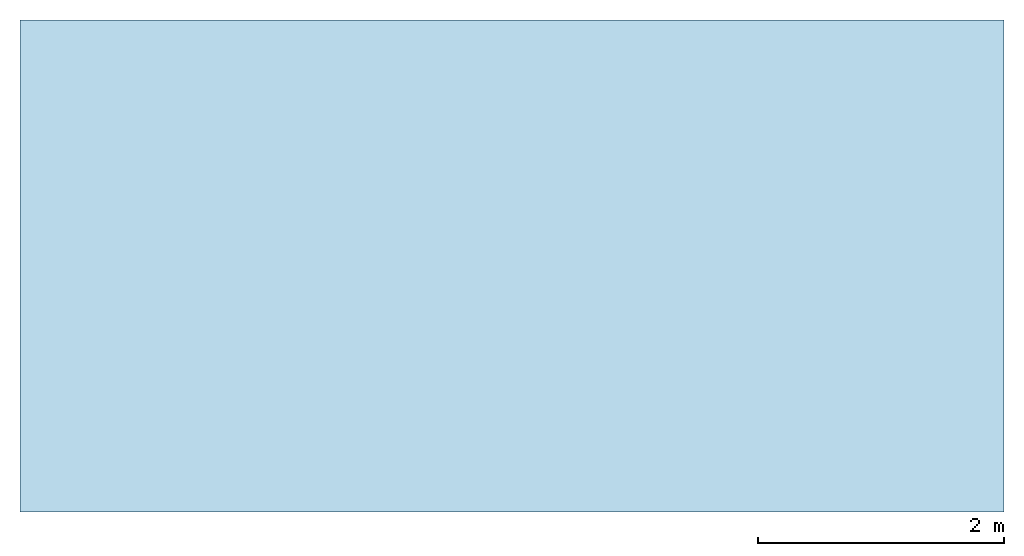
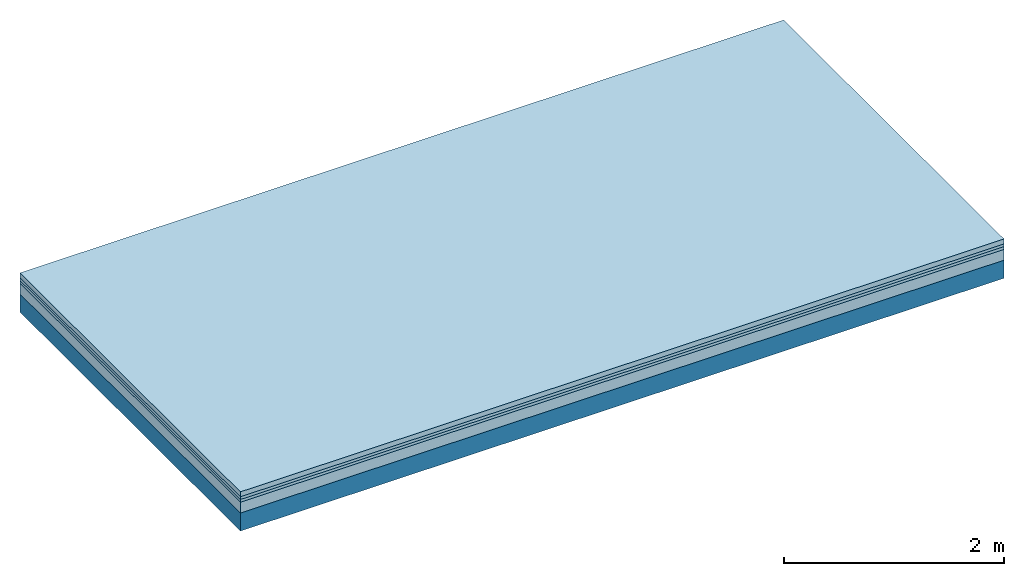
# One storey: 4 plates, 1 member, 1 element without a shape of its own.
"""IFC4 building model written with IfcOpenShell, lengths in metres."""

import ifcopenshell
import ifcopenshell.guid

model = None  # the IFC model being written
_history = None  # IfcOwnerHistory: only IFC2X3 demands one
_inside = {}  # id of a spatial element -> (the spatial element, [elements in it])
_under = {}  # id of a project, library or spatial element -> (it, [spatial elements below it])
_declared = {}  # id of a project -> (the project, [libraries it declares])
_typed = {}  # id of a type object -> (the type object, [elements of that type])
_made_of = {}  # id of a material, layer set ... -> (it, [elements and type objects made of it])


def new_model(schema):
    """Start an empty IFC model of exactly this schema.

    Asked for "IFC4X3", IfcOpenShell would pick the latest addendum, in which some entities
    have other attributes; the version numbers below select the first issue.
    IFC2X3 requires an IfcOwnerHistory on every rooted entity: one is made here for all.
    """
    global model, _history
    if schema == "IFC4X3":
        model = ifcopenshell.file(schema_version=(4, 3, 0, 0))
    else:
        model = ifcopenshell.file(schema=schema)
    _inside.clear()
    _under.clear()
    _declared.clear()
    _typed.clear()
    _made_of.clear()
    _history = None
    if model.schema == "IFC2X3":
        org = make("IfcOrganization", Name="unknown")
        user = make(
            "IfcPersonAndOrganization",
            ThePerson=make("IfcPerson", FamilyName="unknown"),
            TheOrganization=org,
        )
        app = make(
            "IfcApplication",
            ApplicationDeveloper=org,
            Version="unknown",
            ApplicationFullName="unknown",
            ApplicationIdentifier="unknown",
        )
        _history = make(
            "IfcOwnerHistory",
            OwningUser=user,
            OwningApplication=app,
            ChangeAction="ADDED",
            CreationDate=0,
        )
    return model


def make(cls, **values):
    """One entity of the class cls with the attributes given. An attribute that is None is left unset."""
    return model.create_entity(
        cls, **{name: value for name, value in values.items() if value is not None}
    )


def rooted(cls, **values):
    """An entity with a GlobalId (a new one), such as an element, a storey or a relation."""
    return make(cls, GlobalId=ifcopenshell.guid.new(), OwnerHistory=_history, **values)


def si_unit(unit_type, name, prefix=None):
    """IfcSIUnit, for example si_unit("LENGTHUNIT", "METRE", prefix="MILLI")."""
    return make("IfcSIUnit", UnitType=unit_type, Prefix=prefix, Name=name)


def derived_unit(unit_type, elements):
    """IfcDerivedUnit: a product of units, each with its exponent."""
    return make(
        "IfcDerivedUnit",
        Elements=[
            make("IfcDerivedUnitElement", Unit=unit, Exponent=power)
            for unit, power in elements
        ],
        UnitType=unit_type,
    )


def assignment(units):
    """IfcUnitAssignment: the units of a project."""
    return None if units is None else make("IfcUnitAssignment", Units=units)


def point(xyz):
    """IfcCartesianPoint."""
    return None if xyz is None else make("IfcCartesianPoint", Coordinates=xyz)


def direction(xyz):
    """IfcDirection."""
    return None if xyz is None else make("IfcDirection", DirectionRatios=xyz)


def frame(location, z_axis=None, x_axis=None):
    """IfcAxis2Placement3D, a coordinate frame: its origin and axes. An axis left out is left unset."""
    return make(
        "IfcAxis2Placement3D",
        Location=point(location),
        Axis=direction(z_axis),
        RefDirection=direction(x_axis),
    )


def frame_2d(location, x_axis=None):
    """IfcAxis2Placement2D, a coordinate frame in the plane: its origin and x axis."""
    return make(
        "IfcAxis2Placement2D", Location=point(location), RefDirection=direction(x_axis)
    )


def origin():
    """The frame at (0, 0, 0) with its axes left unset."""
    return frame((0.0, 0.0, 0.0))


def origin_with_axes():
    """The frame at (0, 0, 0) with the z axis (0, 0, 1) and the x axis (1, 0, 0) written out."""
    return frame((0.0, 0.0, 0.0), z_axis=(0.0, 0.0, 1.0), x_axis=(1.0, 0.0, 0.0))


def place(relative_to, where):
    """IfcLocalPlacement: puts the frame where relative to a parent placement (None: the world)."""
    return make(
        "IfcLocalPlacement", PlacementRelTo=relative_to, RelativePlacement=where
    )


def context(
    kind, dimensions, precision=None, world=None, true_north=None, identifier=None
):
    """IfcGeometricRepresentationContext, for example the 3D "Model" context."""
    return make(
        "IfcGeometricRepresentationContext",
        ContextIdentifier=identifier,
        ContextType=kind,
        CoordinateSpaceDimension=dimensions,
        Precision=precision,
        WorldCoordinateSystem=world,
        TrueNorth=true_north,
    )


def project(units=None, contexts=None):
    """IfcProject with its units and contexts."""
    return rooted(
        "IfcProject",
        Name="project",
        RepresentationContexts=contexts,
        UnitsInContext=assignment(units),
    )


def spatial(cls, under=None, at=None, **own):
    """A site, building, storey or space (cls), placed at a placement, below another one or the project."""
    s = rooted(cls, ObjectPlacement=at, **own)
    if under is not None:
        _under.setdefault(under.id(), (under, []))[1].append(s)
    return s


def profile(cls, at=None, kind="AREA", **sizes):
    """A parametric profile (cls). Its sizes go by their IFC names, for example OverallWidth=200.0."""
    return make(cls, ProfileType=kind, Position=at, **sizes)


def rectangle(**sizes):
    """IfcRectangleProfileDef."""
    return profile("IfcRectangleProfileDef", **sizes)


def extrude(swept, where, along, depth):
    """IfcExtrudedAreaSolid: the profile swept, set in the frame where, extruded along a direction by depth."""
    return make(
        "IfcExtrudedAreaSolid",
        SweptArea=swept,
        Position=where,
        ExtrudedDirection=direction(along),
        Depth=depth,
    )


def shape(context_of_items, identifier, shape_type, items):
    """IfcShapeRepresentation: the items that make up one representation, for example the "Body"."""
    return make(
        "IfcShapeRepresentation",
        ContextOfItems=context_of_items,
        RepresentationIdentifier=identifier,
        RepresentationType=shape_type,
        Items=items,
    )


def material(Name=None, Category=None):
    """IfcMaterial."""
    return make("IfcMaterial", Name=Name, Category=Category)


def layer(
    of_material, thickness, ventilated=None, Name=None, Category=None, Priority=None
):
    """IfcMaterialLayer: one layer of a wall or slab, of a material (None: an air gap)."""
    return make(
        "IfcMaterialLayer",
        Material=of_material,
        LayerThickness=thickness,
        IsVentilated=ventilated,
        Name=Name,
        Category=Category,
        Priority=Priority,
    )


def layer_set(layers, Name=None):
    """IfcMaterialLayerSet."""
    return make("IfcMaterialLayerSet", MaterialLayers=layers, LayerSetName=Name)


def made_of(thing, what):
    """Note that an element or type object is made of a material, layer set ...; save() writes the relation."""
    if what is not None:
        _made_of.setdefault(what.id(), (what, []))[1].append(thing)
    return thing


def type_object(cls, material=None, **own):
    """A type object (cls), such as IfcWallType, which elements share."""
    return made_of(rooted(cls, **own), material)


def element(
    cls,
    number,
    at=None,
    inside=None,
    cuts=None,
    type_object=None,
    material=None,
    context=None,
    identifier="Body",
    shape_type=None,
    held_by="IfcProductDefinitionShape",
    body=None,
    shapes=None,
    **own,
):
    """One element of the class cls, such as IfcWall. Its Tag is "e" and its number.

    at: its placement. inside: the storey or other place that contains it. cuts: it is an
    opening in that element (IfcRelVoidsElement). A single representation is given by context,
    identifier, shape_type and body (its items); several are given by shapes. held_by: the class
    of the entity that holds the representations. save() writes the other relations.
    """
    e = rooted(cls, Tag="e%d" % number, ObjectPlacement=at, **own)
    if body is not None:
        shapes = [shape(context, identifier, shape_type, body)]
    if shapes is not None:
        e.Representation = make(held_by, Representations=shapes)
    if inside is not None:
        _inside.setdefault(inside.id(), (inside, []))[1].append(e)
    if cuts is not None:
        rooted(
            "IfcRelVoidsElement", RelatingBuildingElement=cuts, RelatedOpeningElement=e
        )
    if type_object is not None:
        _typed.setdefault(type_object.id(), (type_object, []))[1].append(e)
    return made_of(e, material)


def aggregate(whole, parts):
    """IfcRelAggregates: a whole, such as a stair, and the parts it consists of."""
    return rooted("IfcRelAggregates", RelatingObject=whole, RelatedObjects=parts)


def save(model, path):
    """Write the relations noted so far, then the file.

    IfcRelAggregates (storeys below a building ...), IfcRelContainedInSpatialStructure (elements
    in a storey), IfcRelDefinesByType, IfcRelAssociatesMaterial and IfcRelDeclares: one each for
    every whole, place, type object, material and project.
    """
    for whole, parts in _under.values():
        aggregate(whole, parts)
    for where, things in _inside.values():
        rooted(
            "IfcRelContainedInSpatialStructure",
            RelatedElements=things,
            RelatingStructure=where,
        )
    for kind, things in _typed.values():
        rooted("IfcRelDefinesByType", RelatedObjects=things, RelatingType=kind)
    for what, things in _made_of.values():
        rooted("IfcRelAssociatesMaterial", RelatedObjects=things, RelatingMaterial=what)
    for by, libraries in _declared.values():
        rooted("IfcRelDeclares", RelatingContext=by, RelatedDefinitions=libraries)
    model.write(path)


model = new_model("IFC4")

# Units and contexts
plan_context = context("Plan", 3, precision=1e-05, world=origin(), true_north=direction((0.0, 1.0)))
model_context = context("Model", 3, precision=1e-05, world=origin(), true_north=direction((0.0, 1.0)))
ifc_project = project(units=[si_unit("LENGTHUNIT", "METRE"), derived_unit("SOUNDPRESSUREUNIT", [(si_unit("PRESSUREUNIT", "PASCAL", prefix="MICRO"), 0)]), si_unit("ENERGYUNIT", "JOULE", prefix="MEGA"), si_unit("MASSUNIT", "GRAM", prefix="KILO"), derived_unit("THERMALTRANSMITTANCEUNIT", [(si_unit("POWERUNIT", "WATT"), 1), (si_unit("AREAUNIT", "SQUARE_METRE"), -1), (si_unit("THERMODYNAMICTEMPERATUREUNIT", "KELVIN"), -1)]), derived_unit("AREADENSITYUNIT", [(si_unit("MASSUNIT", "GRAM", prefix="KILO"), 1), (si_unit("AREAUNIT", "SQUARE_METRE"), -1)]), derived_unit("USERDEFINED", [(si_unit("ENERGYUNIT", "JOULE", prefix="MEGA"), 1), (si_unit("AREAUNIT", "SQUARE_METRE"), -1)])], contexts=[plan_context, model_context])

# Site, building, storey
site = spatial("IfcSite", under=ifc_project)
building_placement = place(None, origin())
building = spatial("IfcBuilding", under=site, at=building_placement)
storey_placement = place(building_placement, origin())
storey = spatial("IfcBuildingStorey", under=building, at=storey_placement)

# Slab, member, plates
ifc_material_1 = material(Category="04.005")
ifc_layer_1 = layer(ifc_material_1, 0.055, Name="On-material")
ifc_material_2 = material()
ifc_layer_2 = layer(ifc_material_2, 0.03, Name="Impact sound insulation")
ifc_material_3 = material()
ifc_layer_3 = layer(ifc_material_3, 0.03, Name="Additional insulation")
ifc_material_4 = material(Category="03.011")
ifc_layer_4 = layer(ifc_material_4, 0.12, Name="on Supporting structure")
ifc_layer_5 = layer(None, 0.2, Name="Supporting structure")
ifc_layer_set = layer_set([ifc_layer_1, ifc_layer_2, ifc_layer_3, ifc_layer_4, ifc_layer_5])
slab_type = type_object("IfcSlabType", Name="A1099", PredefinedType="NOTDEFINED", material=ifc_layer_set)
slab_placement = place(None, frame((0.0, 0.0, 0.0), z_axis=(0.0, 0.0, -1.0), x_axis=(1.0, 0.0, 0.0)))
slab = element("IfcSlab", 1, at=slab_placement, inside=storey, type_object=slab_type, material=ifc_layer_set, Name="Slab #1")
ifc_material_5 = material()
member_placement = place(slab_placement, origin())
member = element("IfcMember", 2, at=member_placement, material=ifc_material_5, Name="Supporting structure", context=plan_context, shape_type="SweptSolid", body=[
    extrude(rectangle(XDim=1.0, YDim=0.2, at=frame_2d((0.5, 0.1), x_axis=(1.0, 0.0))), frame((0.0, 4.0, 0.235), z_axis=(0.0, -1.0, 0.0), x_axis=(1.0, 0.0, 0.0)), (0.0, 0.0, 1.0), 4.0),
    extrude(rectangle(XDim=1.0, YDim=0.2, at=frame_2d((0.5, 0.1), x_axis=(1.0, 0.0))), frame((1.0, 4.0, 0.235), z_axis=(0.0, -1.0, 0.0), x_axis=(1.0, 0.0, 0.0)), (0.0, 0.0, 1.0), 4.0),
    extrude(rectangle(XDim=1.0, YDim=0.2, at=frame_2d((0.5, 0.1), x_axis=(1.0, 0.0))), frame((2.0, 4.0, 0.235), z_axis=(0.0, -1.0, 0.0), x_axis=(1.0, 0.0, 0.0)), (0.0, 0.0, 1.0), 4.0),
    extrude(rectangle(XDim=1.0, YDim=0.2, at=frame_2d((0.5, 0.1), x_axis=(1.0, 0.0))), frame((3.0, 4.0, 0.235), z_axis=(0.0, -1.0, 0.0), x_axis=(1.0, 0.0, 0.0)), (0.0, 0.0, 1.0), 4.0),
    extrude(rectangle(XDim=1.0, YDim=0.2, at=frame_2d((0.5, 0.1), x_axis=(1.0, 0.0))), frame((4.0, 4.0, 0.235), z_axis=(0.0, -1.0, 0.0), x_axis=(1.0, 0.0, 0.0)), (0.0, 0.0, 1.0), 4.0),
    extrude(rectangle(XDim=1.0, YDim=0.2, at=frame_2d((0.5, 0.1), x_axis=(1.0, 0.0))), frame((5.0, 4.0, 0.235), z_axis=(0.0, -1.0, 0.0), x_axis=(1.0, 0.0, 0.0)), (0.0, 0.0, 1.0), 4.0),
    extrude(rectangle(XDim=1.0, YDim=0.2, at=frame_2d((0.5, 0.1), x_axis=(1.0, 0.0))), frame((6.0, 4.0, 0.235), z_axis=(0.0, -1.0, 0.0), x_axis=(1.0, 0.0, 0.0)), (0.0, 0.0, 1.0), 4.0),
    extrude(rectangle(XDim=1.0, YDim=0.2, at=frame_2d((0.5, 0.1), x_axis=(1.0, 0.0))), frame((7.0, 4.0, 0.235), z_axis=(0.0, -1.0, 0.0), x_axis=(1.0, 0.0, 0.0)), (0.0, 0.0, 1.0), 4.0),
])
plate_1_placement = place(slab_placement, origin())
plate_1 = element("IfcPlate", 3, at=plate_1_placement, material=ifc_material_1, Name="On-material", context=plan_context, shape_type="SweptSolid", body=[
    extrude(rectangle(XDim=8.0, YDim=4.0, at=frame_2d((4.0, 2.0), x_axis=(1.0, 0.0))), origin_with_axes(), (0.0, 0.0, 1.0), 0.055),
])
plate_2_placement = place(slab_placement, origin())
plate_2 = element("IfcPlate", 4, at=plate_2_placement, material=ifc_material_2, Name="Impact sound insulation", context=plan_context, shape_type="SweptSolid", body=[
    extrude(rectangle(XDim=8.0, YDim=4.0, at=frame_2d((4.0, 2.0), x_axis=(1.0, 0.0))), frame((0.0, 0.0, 0.055), z_axis=(0.0, 0.0, 1.0), x_axis=(1.0, 0.0, 0.0)), (0.0, 0.0, 1.0), 0.03),
])
plate_3_placement = place(slab_placement, origin())
plate_3 = element("IfcPlate", 5, at=plate_3_placement, material=ifc_material_3, Name="Additional insulation", context=plan_context, shape_type="SweptSolid", body=[
    extrude(rectangle(XDim=8.0, YDim=4.0, at=frame_2d((4.0, 2.0), x_axis=(1.0, 0.0))), frame((0.0, 0.0, 0.085), z_axis=(0.0, 0.0, 1.0), x_axis=(1.0, 0.0, 0.0)), (0.0, 0.0, 1.0), 0.03),
])
plate_4_placement = place(slab_placement, origin())
plate_4 = element("IfcPlate", 6, at=plate_4_placement, material=ifc_material_4, Name="on Supporting structure", context=plan_context, shape_type="SweptSolid", body=[
    extrude(rectangle(XDim=8.0, YDim=4.0, at=frame_2d((4.0, 2.0), x_axis=(1.0, 0.0))), frame((0.0, 0.0, 0.115), z_axis=(0.0, 0.0, 1.0), x_axis=(1.0, 0.0, 0.0)), (0.0, 0.0, 1.0), 0.12),
])
aggregate(slab, [plate_1, plate_2, plate_3, plate_4, member])

save(model, "model.ifc")
